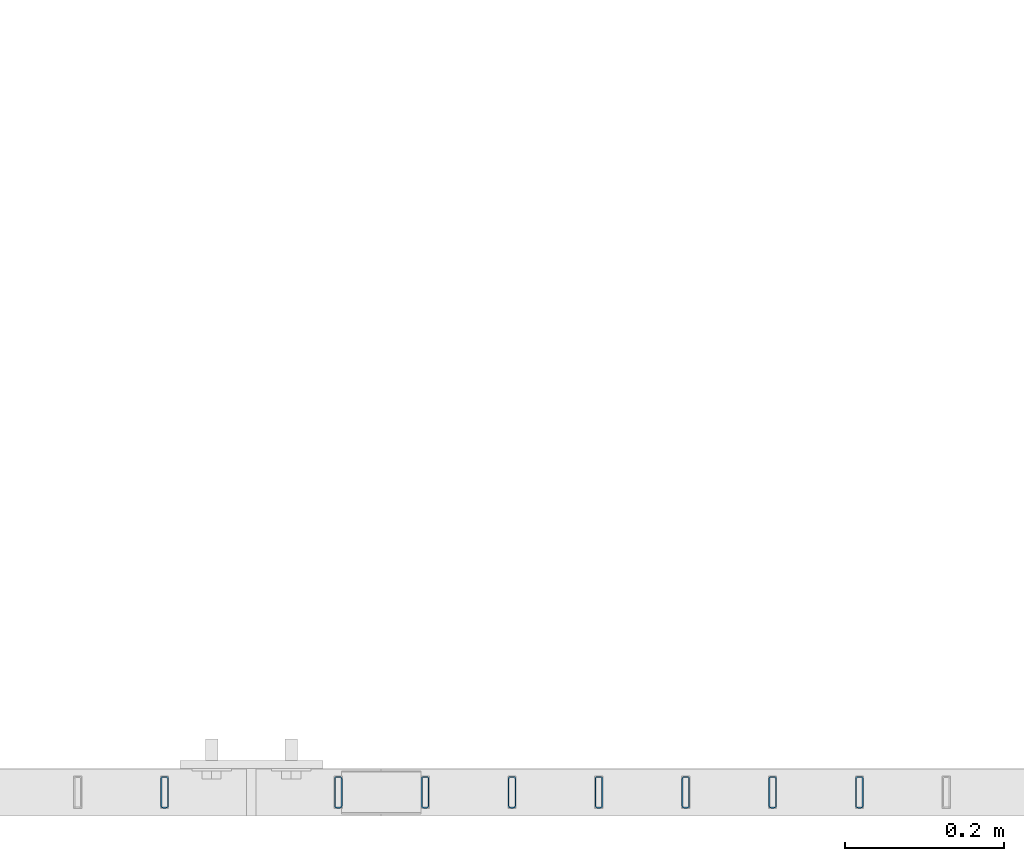
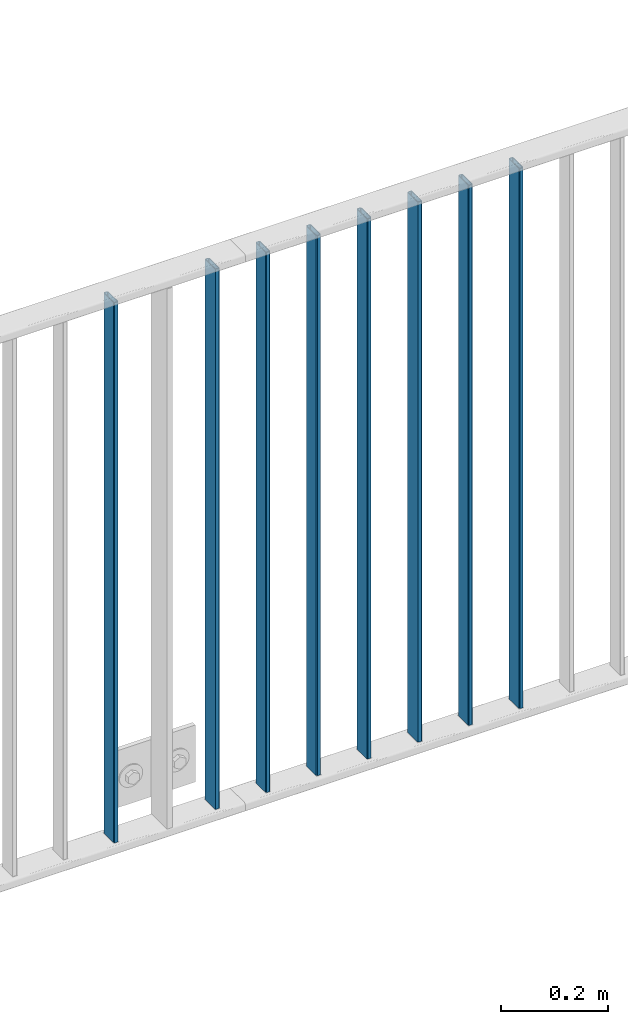
# One storey, part 22 of 156: 8 beams, 2 elements without a shape of their own.
"""IFC2X3 building model written with IfcOpenShell, lengths in millimetres."""

from ifc_helpers import new_model, si_unit, frame, origin_with_axes, origin_2d_with_axis, place, context, subcontext, project, spatial, hollow_rectangle, extrude, clip, halfspace, material, type_object, element, aggregate, save


model = new_model("IFC2X3")

# Units and contexts
model_context = context("Model", 3, precision=1e-05, world=origin_with_axes())
body_context = subcontext(model_context, "Body", "Model", "MODEL_VIEW")
ifc_project = project(units=[si_unit("LENGTHUNIT", "METRE", prefix="MILLI"), si_unit("AREAUNIT", "SQUARE_METRE"), si_unit("VOLUMEUNIT", "CUBIC_METRE"), si_unit("MASSUNIT", "GRAM", prefix="KILO"), si_unit("TIMEUNIT", "SECOND"), si_unit("PLANEANGLEUNIT", "RADIAN"), si_unit("SOLIDANGLEUNIT", "STERADIAN"), si_unit("THERMODYNAMICTEMPERATUREUNIT", "DEGREE_CELSIUS"), si_unit("LUMINOUSINTENSITYUNIT", "LUMEN")], contexts=[model_context])

# Site, building, storey
site_placement = place(None, origin_with_axes())
site = spatial("IfcSite", under=ifc_project, at=site_placement, CompositionType="ELEMENT")
building_placement = place(site_placement, origin_with_axes())
building = spatial("IfcBuilding", under=site, at=building_placement, Name="Undefined", CompositionType="ELEMENT")
storey_placement = place(building_placement, origin_with_axes())
storey = spatial("IfcBuildingStorey", under=building, at=storey_placement, Name="Undefined", CompositionType="ELEMENT", Elevation=0.0)

# Assembly, beams
assembly_1_placement = place(storey_placement, origin_with_axes())
assembly_1 = element("IfcElementAssembly", 1, at=assembly_1_placement, inside=storey, AssemblyPlace="NOTDEFINED", PredefinedType="RIGID_FRAME")
ifc_material = material(Name="STEEL/S235JR")
beam_type = type_object("IfcBeamType", Name="K40/10/1.5", PredefinedType="NOTDEFINED")
beam_1_placement = place(assembly_1_placement, frame((40163.629999999, 8480.00209765299, 3980.00000000003), z_axis=(0.0, 1.0, 0.0), x_axis=(0.0, 0.0, -1.0)))
beam_1 = element("IfcBeam", 2, at=beam_1_placement, type_object=beam_type, material=ifc_material, ObjectType="K40/10/1.5", context=body_context, shape_type="Clipping", body=[
    clip(extrude(hollow_rectangle(XDim=10.0, YDim=40.0, WallThickness=1.5, InnerFilletRadius=1.5, OuterFilletRadius=3.0, at=origin_2d_with_axis()), frame((1230.0, 0.0, 0.0), z_axis=(-1.0, 0.0, 0.0), x_axis=(0.0, -1.0, 0.0)), (0.0, 0.0, 1.0), 1230.0), halfspace(frame((-6.99999999997453, -4.34248751950508, 47.3810900558092), z_axis=(-1.0, 0.0, 0.0), x_axis=(0.0, 0.7683548141934, -0.640024124159258)), False)),
])
beam_2_placement = place(assembly_1_placement, frame((40054.539999999, 8480.00209765299, 3980.00000000003), z_axis=(0.0, 1.0, 0.0), x_axis=(0.0, 0.0, -1.0)))
beam_2 = element("IfcBeam", 3, at=beam_2_placement, type_object=beam_type, material=ifc_material, ObjectType="K40/10/1.5", context=body_context, shape_type="Clipping", body=[
    clip(extrude(hollow_rectangle(XDim=10.0, YDim=40.0, WallThickness=1.5, InnerFilletRadius=1.5, OuterFilletRadius=3.0, at=origin_2d_with_axis()), frame((1230.0, 0.0, 0.0), z_axis=(-1.0, 0.0, 0.0), x_axis=(0.0, -1.0, 0.0)), (0.0, 0.0, 1.0), 1230.0), halfspace(frame((-6.99999999997453, -4.34248751950508, 47.3810900558092), z_axis=(-1.0, 0.0, 0.0), x_axis=(0.0, 0.7683548141934, -0.640024124159258)), False)),
])
beam_3_placement = place(assembly_1_placement, frame((39945.449999999, 8480.00209765299, 3980.00000000003), z_axis=(0.0, 1.0, 0.0), x_axis=(0.0, 0.0, -1.0)))
beam_3 = element("IfcBeam", 4, at=beam_3_placement, type_object=beam_type, material=ifc_material, ObjectType="K40/10/1.5", context=body_context, shape_type="Clipping", body=[
    clip(extrude(hollow_rectangle(XDim=10.0, YDim=40.0, WallThickness=1.5, InnerFilletRadius=1.5, OuterFilletRadius=3.0, at=origin_2d_with_axis()), frame((1230.0, 0.0, 0.0), z_axis=(-1.0, 0.0, 0.0), x_axis=(0.0, -1.0, 0.0)), (0.0, 0.0, 1.0), 1230.0), halfspace(frame((-6.99999999997453, -4.34248751950508, 47.3810900558092), z_axis=(-1.0, 0.0, 0.0), x_axis=(0.0, 0.7683548141934, -0.640024124159258)), False)),
])
beam_4_placement = place(assembly_1_placement, frame((39836.359999999, 8480.00209765299, 3980.00000000003), z_axis=(0.0, 1.0, 0.0), x_axis=(0.0, 0.0, -1.0)))
beam_4 = element("IfcBeam", 5, at=beam_4_placement, type_object=beam_type, material=ifc_material, ObjectType="K40/10/1.5", context=body_context, shape_type="Clipping", body=[
    clip(extrude(hollow_rectangle(XDim=10.0, YDim=40.0, WallThickness=1.5, InnerFilletRadius=1.5, OuterFilletRadius=3.0, at=origin_2d_with_axis()), frame((1230.0, 0.0, 0.0), z_axis=(-1.0, 0.0, 0.0), x_axis=(0.0, -1.0, 0.0)), (0.0, 0.0, 1.0), 1230.0), halfspace(frame((-6.99999999997453, -4.34248751950508, 47.3810900558092), z_axis=(-1.0, 0.0, 0.0), x_axis=(0.0, 0.7683548141934, -0.640024124159258)), False)),
])
beam_5_placement = place(assembly_1_placement, frame((39727.269999999, 8480.00209765299, 3980.00000000003), z_axis=(0.0, 1.0, 0.0), x_axis=(0.0, 0.0, -1.0)))
beam_5 = element("IfcBeam", 6, at=beam_5_placement, type_object=beam_type, material=ifc_material, ObjectType="K40/10/1.5", context=body_context, shape_type="Clipping", body=[
    clip(extrude(hollow_rectangle(XDim=10.0, YDim=40.0, WallThickness=1.5, InnerFilletRadius=1.5, OuterFilletRadius=3.0, at=origin_2d_with_axis()), frame((1230.0, 0.0, 0.0), z_axis=(-1.0, 0.0, 0.0), x_axis=(0.0, -1.0, 0.0)), (0.0, 0.0, 1.0), 1230.0), halfspace(frame((-6.99999999997453, -4.34248751950508, 47.3810900558092), z_axis=(-1.0, 0.0, 0.0), x_axis=(0.0, 0.7683548141934, -0.640024124159258)), False)),
])
beam_6_placement = place(assembly_1_placement, frame((39618.179999999, 8480.00209765299, 3980.00000000003), z_axis=(0.0, 1.0, 0.0), x_axis=(0.0, 0.0, -1.0)))
beam_6 = element("IfcBeam", 7, at=beam_6_placement, type_object=beam_type, material=ifc_material, ObjectType="K40/10/1.5", context=body_context, shape_type="Clipping", body=[
    clip(extrude(hollow_rectangle(XDim=10.0, YDim=40.0, WallThickness=1.5, InnerFilletRadius=1.5, OuterFilletRadius=3.0, at=origin_2d_with_axis()), frame((1230.0, 0.0, 0.0), z_axis=(-1.0, 0.0, 0.0), x_axis=(0.0, -1.0, 0.0)), (0.0, 0.0, 1.0), 1230.0), halfspace(frame((-6.99999999997453, -4.34248751950508, 47.3810900558092), z_axis=(-1.0, 0.0, 0.0), x_axis=(0.0, 0.7683548141934, -0.640024124159258)), False)),
])
aggregate(assembly_1, [beam_1, beam_2, beam_3, beam_4, beam_5, beam_6])

assembly_2_placement = place(storey_placement, origin_with_axes())
assembly_2 = element("IfcElementAssembly", 8, at=assembly_2_placement, inside=storey, AssemblyPlace="NOTDEFINED", PredefinedType="RIGID_FRAME")
beam_7_placement = place(assembly_2_placement, frame((39509.089999999, 8480.00209765299, 3980.00000000003), z_axis=(0.0, 1.0, 0.0), x_axis=(0.0, 0.0, -1.0)))
beam_7 = element("IfcBeam", 9, at=beam_7_placement, type_object=beam_type, material=ifc_material, ObjectType="K40/10/1.5", context=body_context, shape_type="Clipping", body=[
    clip(extrude(hollow_rectangle(XDim=10.0, YDim=40.0, WallThickness=1.5, InnerFilletRadius=1.5, OuterFilletRadius=3.0, at=origin_2d_with_axis()), frame((1230.0, 0.0, 0.0), z_axis=(-1.0, 0.0, 0.0), x_axis=(0.0, -1.0, 0.0)), (0.0, 0.0, 1.0), 1230.0), halfspace(frame((-6.99999999997453, -4.34248751950508, 47.3810900558092), z_axis=(-1.0, 0.0, 0.0), x_axis=(0.0, 0.7683548141934, -0.640024124159258)), False)),
])
beam_8_placement = place(assembly_2_placement, frame((39290.899999999, 8480.00209765299, 3980.00000000003), z_axis=(0.0, 1.0, 0.0), x_axis=(0.0, 0.0, -1.0)))
beam_8 = element("IfcBeam", 10, at=beam_8_placement, type_object=beam_type, material=ifc_material, ObjectType="K40/10/1.5", context=body_context, shape_type="Clipping", body=[
    clip(extrude(hollow_rectangle(XDim=10.0, YDim=40.0, WallThickness=1.5, InnerFilletRadius=1.5, OuterFilletRadius=3.0, at=origin_2d_with_axis()), frame((1230.0, 0.0, 0.0), z_axis=(-1.0, 0.0, 0.0), x_axis=(0.0, -1.0, 0.0)), (0.0, 0.0, 1.0), 1230.0), halfspace(frame((-6.99999999997453, -4.34248751950508, 47.3810900558092), z_axis=(-1.0, 0.0, 0.0), x_axis=(0.0, 0.7683548141934, -0.640024124159258)), False)),
])
aggregate(assembly_2, [beam_7, beam_8])

save(model, "model.ifc")
